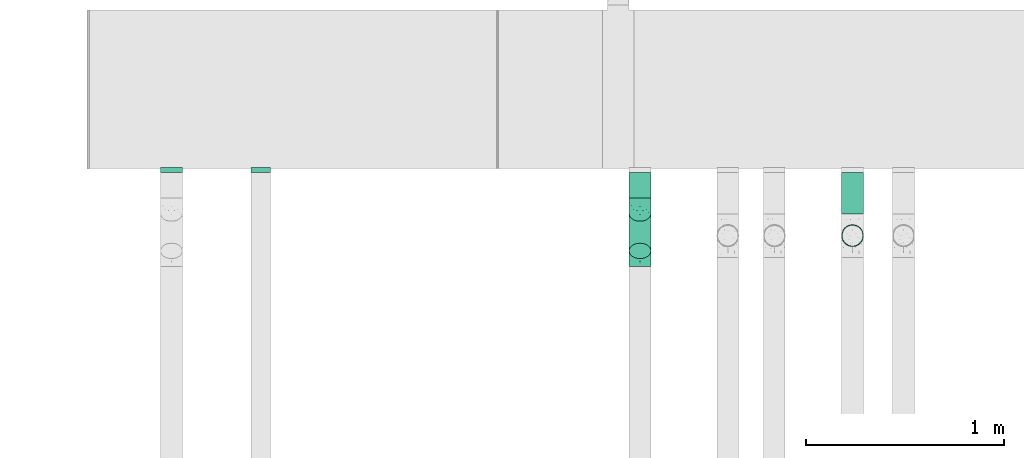
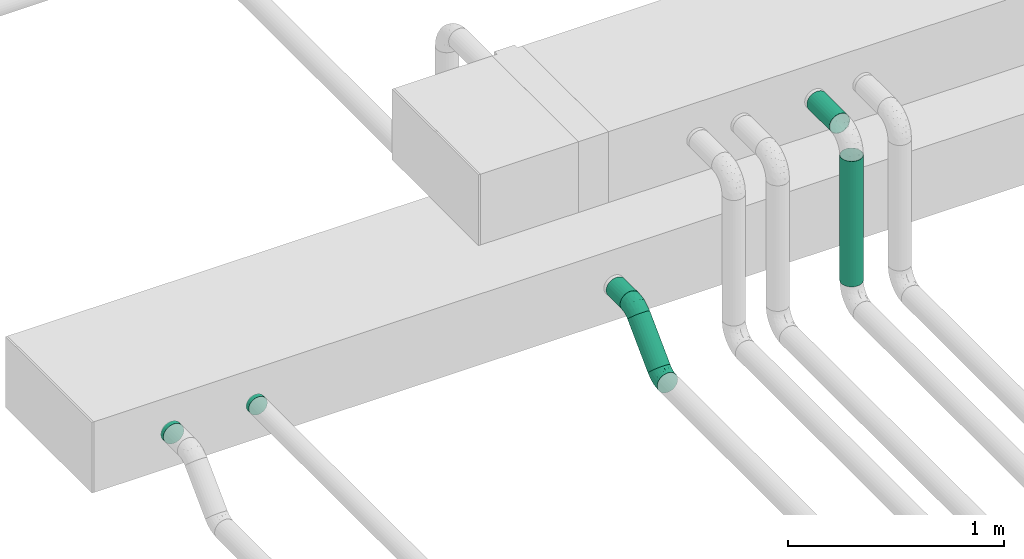
# One storey, part 6 of 91: 4 flow fittings, 4 flow segments.
"""IFC2X3 building model written with IfcOpenShell, lengths in millimetres."""

from ifc_helpers import new_model, entity, si_unit, converted_unit, derived_unit, direction, frame, origin_with_axes, origin_2d_with_axis, place, context, subcontext, project, spatial, hollow_circle, extrude, open_shell, surface_model, source, transform, mapped, material, layer, layer_set, layer_usage, type_object, element, save


model = new_model("IFC2X3")

# Units and contexts
model_context = context("Model", 3, precision=1e-05, world=origin_with_axes(), true_north=direction((0.0, 1.0)))
body_context = subcontext(model_context, "Body", "Model", "MODEL_VIEW")
ifc_project = project(units=[si_unit("AREAUNIT", "SQUARE_METRE"), si_unit("VOLUMEUNIT", "CUBIC_METRE", prefix="DECI"), si_unit("TIMEUNIT", "SECOND"), si_unit("THERMODYNAMICTEMPERATUREUNIT", "DEGREE_CELSIUS"), si_unit("PRESSUREUNIT", "PASCAL"), si_unit("MASSUNIT", "GRAM", prefix="KILO"), si_unit("LENGTHUNIT", "METRE", prefix="MILLI"), si_unit("POWERUNIT", "WATT"), si_unit("ELECTRICCURRENTUNIT", "AMPERE"), si_unit("ELECTRICVOLTAGEUNIT", "VOLT"), derived_unit("VOLUMETRICFLOWRATEUNIT", [(si_unit("VOLUMEUNIT", "CUBIC_METRE", prefix="DECI"), 1), (si_unit("TIMEUNIT", "SECOND"), -1)]), derived_unit("LINEARVELOCITYUNIT", [(si_unit("LENGTHUNIT", "METRE"), 1), (si_unit("TIMEUNIT", "SECOND"), -1)]), derived_unit("MASSDENSITYUNIT", [(si_unit("MASSUNIT", "GRAM", prefix="KILO"), 1), (si_unit("VOLUMEUNIT", "CUBIC_METRE"), -1)]), converted_unit("PLANEANGLEUNIT", "DEGREE", entity("IfcRatioMeasure", 0.01745), si_unit("PLANEANGLEUNIT", "RADIAN"), dimensions=[0, 0, 0, 0, 0, 0, 0])], contexts=[model_context])

# Site, building, storey
site_placement = place(None, origin_with_axes())
site = spatial("IfcSite", under=ifc_project, at=site_placement, CompositionType="ELEMENT")
building_placement = place(site_placement, origin_with_axes())
building = spatial("IfcBuilding", under=site, at=building_placement, Name="mc-building", CompositionType="ELEMENT")
storey_placement = place(building_placement, frame((0.0, 0.0, 8700.0), z_axis=(0.0, 0.0, 1.0), x_axis=(1.0, 0.0, 0.0)))
storey = spatial("IfcBuildingStorey", under=building, at=storey_placement, CompositionType="ELEMENT", Elevation=8700.0)

# Flow segments
ifc_material = material(Name="FZ1")
ifc_layer = layer(ifc_material, 0.0)
ifc_layer_set = layer_set([ifc_layer], Name="FZ1")
ifc_layer_usage = layer_usage(ifc_layer_set, "AXIS1", "POSITIVE", 0.0)
duct_segment_type = type_object("IfcDuctSegmentType", PredefinedType="RIGIDSEGMENT")
shared_shape_1 = source(origin_with_axes(), body_context, "Body", "SweptSolid", [
    extrude(hollow_circle(Radius=55.0, WallThickness=2.0, at=origin_2d_with_axis()), frame((0.0, 0.0, 0.0), z_axis=(1.0, 0.0, 0.0), x_axis=(0.0, 1.0, 0.0)), (0.0, 0.0, 1.0), 709.0),
])
flow_segment_1_placement = place(storey_placement, frame((8987.56202, 2612.35324, 1234.0), z_axis=(0.0, 1.0, 0.0), x_axis=(0.0, 0.0, -1.0)))
element("IfcFlowSegment", 1, at=flow_segment_1_placement, inside=storey, type_object=duct_segment_type, material=ifc_layer_usage, context=body_context, shape_type="MappedRepresentation", body=[
    mapped(shared_shape_1, transform((0.0, 0.0, 0.0), scale=1.0)),
])
shared_shape_2 = source(origin_with_axes(), body_context, "Body", "SweptSolid", [
    extrude(hollow_circle(Radius=55.0, WallThickness=2.0, at=origin_2d_with_axis()), frame((0.0, 0.0, 0.0), z_axis=(1.0, 0.0, 0.0), x_axis=(0.0, 1.0, 0.0)), (0.0, 0.0, 1.0), 208.9),
])
flow_segment_2_placement = place(storey_placement, frame((8987.56202, 2931.20513, 1344.0), z_axis=(0.0, 0.0, 1.0), x_axis=(0.0, -1.0, 0.0)))
element("IfcFlowSegment", 2, at=flow_segment_2_placement, inside=storey, type_object=duct_segment_type, material=ifc_layer_usage, context=body_context, shape_type="MappedRepresentation", body=[
    mapped(shared_shape_2, transform((0.0, 0.0, 0.0), scale=1.0, scale2=1.0, scale3=1.0, uniform=False)),
])
shared_shape_3 = source(origin_with_axes(), body_context, "Body", "SweptSolid", [
    extrude(hollow_circle(Radius=55.0, WallThickness=2.0, at=origin_2d_with_axis()), frame((0.0, 0.0, 0.0), z_axis=(1.0, 0.0, 0.0), x_axis=(0.0, 1.0, 0.0)), (0.0, 0.0, 1.0), 266.7),
])
flow_segment_3_placement = place(storey_placement, frame((7914.47808, 2723.75077, 635.78175), z_axis=(0.0, -0.707107, 0.707107), x_axis=(0.0, -0.707107, -0.707107)))
element("IfcFlowSegment", 3, at=flow_segment_3_placement, inside=storey, type_object=duct_segment_type, material=ifc_layer_usage, context=body_context, shape_type="MappedRepresentation", body=[
    mapped(shared_shape_3, transform((0.0, 0.0, 0.0), scale=1.0)),
])

# Flow fittings
duct_fitting_type_1 = type_object("IfcDuctFittingType", Name="BU", PredefinedType="BEND")
shared_shape_4 = source(origin_with_axes(), body_context, "Body", "SurfaceModel", [
    surface_model("IfcShellBasedSurfaceModel", [(-45.56349, 0.0, -55.0), (-45.56349, -14.23505, -53.12592), (-45.56349, 14.23505, -53.12592), (-45.56349, 53.12592, 14.23505), (-45.56349, 27.5, -47.63139), (-45.56349, 38.89087, -38.89087), (-45.56349, 47.63139, -27.5), (-45.56349, -55.0, 0.0), (-45.56349, -53.12592, 14.23505), (-45.56349, -38.89087, -38.89087), (-45.56349, -27.5, -47.63139), (-45.56349, -53.12592, -14.23505), (-45.56349, -47.63139, -27.5), (-45.56349, 53.12592, -14.23505), (-45.56349, 47.63139, 27.5), (-45.56349, 38.89087, 38.89087), (-45.56349, -14.23505, 53.12592), (-45.56349, 27.5, 47.63139), (-45.56349, 14.23505, 53.12592), (-45.56349, -47.63139, 27.5), (-45.56349, -38.89087, 38.89087), (-45.56349, -27.5, 47.63139), (-45.56349, 0.0, 55.0), (-45.56349, 55.0, 0.0), (22.15256, 42.28395, -53.12592), (-6.67262, 71.10913, 0.0), (32.21826, 32.21826, -55.0), (12.77282, 51.66369, -47.63139), (-1.46223, 65.89874, -27.5), (4.71825, 59.71825, -38.89087), (59.71825, 4.71825, -38.89087), (69.78395, -5.34744, 14.23505), (51.66369, 12.77282, -47.63139), (42.28395, 22.15256, -53.12592), (65.89874, -1.46223, -27.5), (69.78395, -5.34744, -14.23505), (71.10913, -6.67262, 0.0), (-5.34744, 69.78395, -14.23505), (-5.34744, 69.78395, 14.23505), (-1.46223, 65.89874, 27.5), (4.71825, 59.71825, 38.89087), (32.21826, 32.21826, 55.0), (12.77282, 51.66369, 47.63139), (22.15256, 42.28395, 53.12592), (59.71825, 4.71825, 38.89087), (65.89874, -1.46223, 27.5), (42.28395, 22.15256, 53.12592), (51.66369, 12.77282, 47.63139), (-20.16649, 48.68621, 33.48188), (-26.97111, 35.77503, 43.63444), (-7.30443, 43.73336, 43.63444), (-17.0934, 3.74816, 55.0), (-18.00408, 15.44793, 53.78143), (-30.11707, 22.39897, 50.81337), (-7.49776, 55.63651, 33.48188), (-15.97018, 58.74288, 21.04759), (-31.18231, 52.58712, 21.04759), (-18.35174, 61.03934, 10.51509), (-28.67677, 56.60048, 10.47121), (-34.03924, 44.64267, 33.48188), (-11.52288, 27.81868, 50.81338), (1.19951, 23.16465, 53.81115), (-33.77926, 57.34403, 0.0), (5.4586, 37.12132, 50.81809), (-24.5159, 59.18663, 0.0), (-16.66281, 64.4339, 0.0), (9.43651, 14.73721, 55.0), (-6.22531, 44.36822, -43.63444), (5.4586, 37.12132, -50.81809), (-34.03924, 44.64267, -33.48188), (9.43651, 14.73721, -55.0), (-17.0934, 3.74816, -55.0), (1.19951, 23.16465, -53.81115), (-11.52288, 27.81868, -50.81338), (-30.11707, 22.39897, -50.81337), (-25.75914, 36.08917, -43.63444), (-30.24487, 52.83011, -21.04759), (-20.16649, 48.68621, -33.48188), (-7.49776, 55.63651, -33.48188), (-18.00408, 15.44793, -53.78143), (-28.68366, 56.62226, -10.35271), (-14.15883, 63.53074, -10.87592), (-15.13548, 59.23394, -21.04759), (3.19797, -7.72059, -52.16847), (3.1272, -18.04126, -47.9241), (13.63233, -32.91136, -32.06475), (45.23618, -22.99734, -20.4997), (16.67434, -40.25541, -15.9539), (-17.3935, -51.68264, -9.80849), (-2.85835, -49.37776, 0.0), (48.84421, -24.24609, -9.80849), (-16.38424, -42.76862, -30.85433), (-6.97383, -29.41689, -42.70541), (41.82739, -18.65658, -30.85433), (-15.72523, -48.24839, -20.4997), (29.28945, -13.63928, -42.80781), (26.81493, -3.56603, -49.15704), (36.93651, -32.89419, 0.0), (-15.72523, -48.24839, 20.4997), (-17.3935, -51.68264, 9.80849), (-16.38424, -42.76862, 30.85433), (16.67434, -40.25541, 15.9539), (3.19797, -7.72059, 52.16847), (10.54583, -14.96836, 47.9241), (13.63233, -32.91136, 32.06475), (45.23618, -22.99734, 20.4997), (41.82739, -18.65658, 30.85433), (-11.06635, -30.3552, 42.80781), (25.73213, -15.86964, 42.70541), (-16.43945, -21.48258, 49.15704), (48.84421, -24.24609, 9.80849)], [open_shell([[[0, 1, 2]], [[2, 3, 4]], [[5, 3, 6]], [[4, 3, 5]], [[2, 7, 8]], [[9, 7, 10]], [[1, 10, 7]], [[11, 7, 12]], [[9, 12, 7]], [[7, 2, 1]], [[13, 6, 3]], [[14, 3, 2]], [[15, 14, 2]], [[16, 17, 2]], [[2, 17, 15]], [[16, 18, 17]], [[19, 20, 2]], [[19, 2, 8]], [[20, 21, 2]], [[2, 21, 16]], [[16, 22, 18]], [[23, 13, 3]], [[24, 25, 26]], [[27, 25, 24]], [[28, 25, 29]], [[29, 25, 27]], [[30, 26, 31]], [[26, 30, 32]], [[32, 33, 26]], [[34, 31, 35]], [[31, 34, 30]], [[35, 31, 36]], [[37, 25, 28]], [[26, 38, 39]], [[26, 39, 40]], [[41, 40, 42]], [[26, 40, 41]], [[42, 43, 41]], [[26, 44, 45]], [[31, 26, 45]], [[46, 47, 26]], [[47, 44, 26]], [[46, 26, 41]], [[26, 25, 38]], [[48, 49, 50]], [[22, 51, 52]], [[17, 49, 15]], [[53, 17, 18]], [[49, 17, 53]], [[54, 50, 40]], [[48, 55, 56]], [[55, 57, 58]], [[59, 14, 15]], [[60, 53, 52]], [[50, 49, 60]], [[58, 3, 56]], [[52, 51, 61]], [[62, 23, 3]], [[63, 50, 60]], [[50, 42, 40]], [[3, 58, 62]], [[43, 61, 41]], [[62, 58, 64]], [[48, 59, 49]], [[14, 56, 3]], [[40, 39, 54]], [[57, 64, 58]], [[39, 38, 55]], [[63, 60, 61]], [[54, 55, 48]], [[65, 57, 38]], [[56, 14, 59]], [[38, 25, 65]], [[60, 52, 61]], [[49, 59, 15]], [[55, 58, 56]], [[56, 59, 48]], [[55, 54, 39]], [[50, 54, 48]], [[18, 22, 52]], [[49, 53, 60]], [[18, 52, 53]], [[61, 51, 66]], [[41, 61, 66]], [[63, 61, 43]], [[43, 42, 63]], [[50, 63, 42]], [[38, 57, 55]], [[64, 57, 65]], [[67, 27, 68]], [[69, 5, 6]], [[70, 71, 72]], [[73, 74, 75]], [[76, 77, 69]], [[29, 78, 28]], [[2, 79, 0]], [[13, 23, 62]], [[2, 74, 79]], [[5, 75, 4]], [[77, 78, 67]], [[13, 62, 80]], [[64, 80, 62]], [[81, 80, 64]], [[67, 73, 75]], [[82, 77, 76]], [[81, 64, 65]], [[76, 69, 6]], [[82, 76, 80]], [[24, 72, 68]], [[74, 2, 4]], [[27, 67, 29]], [[26, 70, 72]], [[69, 75, 5]], [[82, 28, 78]], [[72, 71, 79]], [[6, 13, 76]], [[77, 67, 75]], [[13, 80, 76]], [[82, 37, 28]], [[81, 25, 37]], [[82, 81, 37]], [[75, 69, 77]], [[67, 78, 29]], [[82, 78, 77]], [[75, 74, 4]], [[79, 74, 73]], [[79, 73, 72]], [[79, 71, 0]], [[68, 72, 73]], [[26, 72, 24]], [[67, 68, 73]], [[27, 24, 68]], [[80, 81, 82]], [[25, 81, 65]], [[1, 83, 84]], [[85, 86, 87]], [[0, 71, 1]], [[88, 87, 89]], [[90, 86, 35]], [[91, 92, 85]], [[11, 88, 7]], [[30, 34, 93]], [[11, 12, 94]], [[92, 91, 9]], [[85, 94, 91]], [[94, 85, 87]], [[95, 93, 85]], [[85, 92, 95]], [[83, 71, 70]], [[12, 9, 91]], [[70, 26, 33]], [[96, 84, 83]], [[1, 71, 83]], [[95, 96, 32]], [[95, 30, 93]], [[95, 32, 30]], [[97, 89, 87]], [[34, 86, 93]], [[36, 97, 90]], [[94, 88, 11]], [[34, 35, 86]], [[90, 87, 86]], [[93, 86, 85]], [[32, 96, 33]], [[84, 10, 1]], [[33, 83, 70]], [[94, 12, 91]], [[10, 92, 9]], [[87, 88, 94]], [[7, 88, 89]], [[36, 90, 35]], [[87, 90, 97]], [[84, 95, 92]], [[33, 96, 83]], [[95, 84, 96]], [[10, 84, 92]], [[8, 98, 19]], [[7, 89, 99]], [[19, 98, 100]], [[101, 98, 99]], [[46, 102, 103]], [[104, 105, 106]], [[100, 98, 104]], [[107, 104, 108]], [[16, 51, 22]], [[51, 16, 102]], [[107, 20, 100]], [[107, 109, 21]], [[21, 20, 107]], [[103, 47, 46]], [[101, 89, 97]], [[105, 110, 31]], [[44, 47, 108]], [[105, 104, 101]], [[107, 100, 104]], [[31, 110, 36]], [[109, 16, 21]], [[108, 106, 44]], [[105, 45, 106]], [[41, 66, 46]], [[102, 66, 51]], [[46, 66, 102]], [[104, 98, 101]], [[99, 98, 8]], [[106, 108, 104]], [[110, 101, 97]], [[45, 44, 106]], [[105, 31, 45]], [[20, 19, 100]], [[109, 103, 102]], [[101, 110, 105]], [[36, 110, 97]], [[7, 99, 8]], [[101, 99, 89]], [[103, 107, 108]], [[16, 109, 102]], [[107, 103, 109]], [[47, 103, 108]]])]),
])
for number, where, z_axis, x_axis, name in (
    (4, (7914.47808, 2755.96902, 668.0), (-1.0, 0.0, 0.0), (0.0, 0.707107, 0.707107), "BU"),
    (5, (7914.47808, 2502.96902, 415.0), (1.0, 0.0, 0.0), (0.0, 1.0, 0.0), "BU"),
):
    element("IfcFlowFitting", number, at=place(storey_placement, frame(where, z_axis=z_axis, x_axis=x_axis)), inside=storey, type_object=duct_fitting_type_1, Name=name, context=body_context, shape_type="MappedRepresentation", body=[
        mapped(shared_shape_4, transform((0.0, 0.0, 0.0), scale=1.0)),
    ])

# Flow segment
shared_shape_5 = source(origin_with_axes(), body_context, "Body", "SweptSolid", [
    extrude(hollow_circle(Radius=55.0, WallThickness=2.0, at=origin_2d_with_axis()), frame((0.0, 0.0, 0.0), z_axis=(1.0, 0.0, 0.0), x_axis=(0.0, 1.0, 0.0)), (0.0, 0.0, 1.0), 129.7),
])
flow_segment_4_placement = place(storey_placement, frame((7914.47808, 2931.20513, 668.0), z_axis=(0.0, 0.0, 1.0), x_axis=(0.0, -1.0, 0.0)))
element("IfcFlowSegment", 6, at=flow_segment_4_placement, inside=storey, type_object=duct_segment_type, material=ifc_layer_usage, context=body_context, shape_type="MappedRepresentation", body=[
    mapped(shared_shape_5, transform((0.0, 0.0, 0.0), scale=1.0)),
])

# Flow fittings
duct_fitting_type_2 = type_object("IfcDuctFittingType", Name="CC", PredefinedType="CONNECTOR")
shared_shape_6 = source(origin_with_axes(), body_context, "Body", "SurfaceModel", [
    surface_model("IfcShellBasedSurfaceModel", [(-6.096, -38.89087, -38.89087), (-6.096, -55.0, 0.0), (-6.096, -27.5, -47.63139), (-6.096, 47.63139, -27.5), (-6.096, 53.12592, 14.23505), (-6.096, 53.12592, -14.23505), (-6.096, 55.0, 0.0), (-6.096, -53.12592, -14.23505), (-6.096, -47.63139, -27.5), (20.0, 38.89087, -38.89087), (20.0, 55.0, 0.0), (20.0, 27.5, -47.63139), (20.0, 53.12592, -14.23505), (20.0, 47.63139, -27.5), (20.0, -47.63139, -27.5), (20.0, -53.12592, 14.23505), (20.0, -53.12592, -14.23505), (20.0, -55.0, 0.0), (-6.096, 0.0, -55.0), (-6.096, -14.23505, -53.12592), (-6.096, 14.23505, -53.12592), (-6.096, 27.5, -47.63139), (-6.096, 38.89087, -38.89087), (-6.096, -53.12592, 14.23505), (-6.096, 47.63139, 27.5), (-6.096, 38.89087, 38.89087), (-6.096, -14.23505, 53.12592), (-6.096, 27.5, 47.63139), (-6.096, 14.23505, 53.12592), (-6.096, -47.63139, 27.5), (-6.096, -38.89087, 38.89087), (-6.096, -27.5, 47.63139), (-6.096, 0.0, 55.0), (0.0, 0.0, 55.0), (0.0, 14.23505, 53.12592), (0.0, 27.5, 47.63139), (0.0, 38.89087, 38.89087), (0.0, 47.63139, 27.5), (0.0, 53.12592, 14.23505), (0.0, 55.0, 0.0), (0.0, 53.12592, -14.23505), (0.0, 47.63139, -27.5), (0.0, 38.89087, -38.89087), (0.0, 27.5, -47.63139), (0.0, 14.23505, -53.12592), (0.0, 0.0, -55.0), (0.0, -14.23505, -53.12592), (0.0, -27.5, -47.63139), (0.0, -38.89087, -38.89087), (0.0, -47.63139, -27.5), (0.0, -53.12592, -14.23505), (0.0, -55.0, 0.0), (0.0, -53.12592, 14.23505), (0.0, -47.63139, 27.5), (0.0, -38.89087, 38.89087), (0.0, -27.5, 47.63139), (0.0, -14.23505, 53.12592), (20.0, 0.0, -55.0), (20.0, 14.23505, -53.12592), (20.0, -38.89087, -38.89087), (20.0, -27.5, -47.63139), (20.0, -14.23505, -53.12592), (20.0, 53.12592, 14.23505), (20.0, 47.63139, 27.5), (20.0, 38.89087, 38.89087), (20.0, 0.0, 55.0), (20.0, 27.5, 47.63139), (20.0, 14.23505, 53.12592), (20.0, -38.89087, 38.89087), (20.0, -47.63139, 27.5), (20.0, -14.23505, 53.12592), (20.0, -27.5, 47.63139)], [open_shell([[[0, 1, 2]], [[3, 4, 5]], [[6, 5, 4]], [[7, 1, 8]], [[9, 10, 11]], [[12, 10, 13]], [[14, 15, 16]], [[17, 16, 15]], [[18, 19, 20]], [[20, 4, 21]], [[3, 22, 4]], [[21, 4, 22]], [[20, 1, 23]], [[19, 2, 1]], [[0, 8, 1]], [[1, 20, 19]], [[20, 24, 4]], [[25, 24, 20]], [[26, 27, 20]], [[27, 25, 20]], [[26, 28, 27]], [[20, 29, 30]], [[29, 20, 23]], [[30, 31, 20]], [[20, 31, 26]], [[26, 32, 28]], [[32, 33, 34]], [[28, 34, 35]], [[32, 34, 28]], [[27, 36, 25]], [[27, 28, 35]], [[36, 27, 35]], [[24, 37, 38]], [[4, 38, 39]], [[25, 37, 24]], [[4, 24, 38]], [[6, 4, 39]], [[37, 25, 36]], [[6, 39, 40]], [[5, 40, 41]], [[6, 40, 5]], [[3, 42, 22]], [[3, 5, 41]], [[42, 3, 41]], [[21, 43, 44]], [[20, 44, 45]], [[22, 43, 21]], [[20, 21, 44]], [[18, 20, 45]], [[43, 22, 42]], [[18, 45, 46]], [[19, 46, 47]], [[18, 46, 19]], [[2, 48, 0]], [[2, 19, 47]], [[48, 2, 47]], [[8, 49, 50]], [[7, 50, 51]], [[0, 49, 8]], [[7, 8, 50]], [[1, 7, 51]], [[49, 0, 48]], [[1, 51, 52]], [[23, 52, 53]], [[1, 52, 23]], [[29, 54, 30]], [[29, 23, 53]], [[54, 29, 53]], [[31, 55, 56]], [[26, 56, 33]], [[30, 55, 31]], [[26, 31, 56]], [[32, 26, 33]], [[55, 30, 54]], [[10, 57, 58]], [[11, 10, 58]], [[10, 9, 13]], [[59, 57, 15]], [[57, 59, 60]], [[60, 61, 57]], [[59, 15, 14]], [[62, 63, 57]], [[57, 63, 64]], [[65, 64, 66]], [[65, 57, 64]], [[67, 65, 66]], [[68, 69, 57]], [[15, 57, 69]], [[70, 71, 57]], [[71, 68, 57]], [[70, 57, 65]], [[10, 62, 57]], [[33, 65, 67]], [[34, 67, 66]], [[33, 67, 34]], [[35, 64, 36]], [[35, 34, 66]], [[64, 35, 66]], [[37, 63, 62]], [[38, 62, 10]], [[36, 63, 37]], [[38, 37, 62]], [[39, 38, 10]], [[63, 36, 64]], [[39, 10, 12]], [[40, 12, 13]], [[39, 12, 40]], [[41, 9, 42]], [[41, 40, 13]], [[9, 41, 13]], [[43, 11, 58]], [[44, 58, 57]], [[42, 11, 43]], [[44, 43, 58]], [[45, 44, 57]], [[11, 42, 9]], [[45, 57, 61]], [[46, 61, 60]], [[45, 61, 46]], [[47, 59, 48]], [[47, 46, 60]], [[59, 47, 60]], [[49, 14, 16]], [[50, 16, 17]], [[48, 14, 49]], [[50, 49, 16]], [[51, 50, 17]], [[14, 48, 59]], [[51, 17, 15]], [[52, 15, 69]], [[51, 15, 52]], [[53, 68, 54]], [[53, 52, 69]], [[68, 53, 69]], [[55, 71, 70]], [[56, 70, 65]], [[54, 71, 55]], [[56, 55, 70]], [[33, 56, 65]], [[71, 54, 68]], [[65, 57, 66]], [[57, 64, 66]], [[65, 66, 67]], [[69, 15, 57]]])]),
])
flow_fitting_1_placement = place(storey_placement, frame((5548.85991, 2951.20513, 668.0), z_axis=(0.0, 0.0, -1.0), x_axis=(0.0, -1.0, 0.0)))
element("IfcFlowFitting", 7, at=flow_fitting_1_placement, inside=storey, type_object=duct_fitting_type_2, Name="CC", context=body_context, shape_type="MappedRepresentation", body=[
    mapped(shared_shape_6, transform((0.0, 0.0, 0.0), scale=1.0)),
])
shared_shape_7 = source(origin_with_axes(), body_context, "Body", "SurfaceModel", [
    surface_model("IfcShellBasedSurfaceModel", [(-6.096, -35.35534, -35.35534), (-6.096, -50.0, 0.0), (-6.096, -25.0, -43.30127), (-6.096, 43.30127, -25.0), (-6.096, 48.29629, 12.94095), (-6.096, 48.29629, -12.94095), (20.0, -43.30127, -25.0), (20.0, -35.35534, -35.35534), (20.0, -48.29629, 12.94095), (20.0, 35.35534, -35.35534), (20.0, 50.0, 0.0), (20.0, 25.0, -43.30127), (20.0, -48.29629, -12.94095), (20.0, -50.0, 0.0), (-6.096, 0.0, -50.0), (-6.096, -12.94095, -48.29629), (-6.096, 12.94095, -48.29629), (-6.096, 25.0, -43.30127), (-6.096, 35.35534, -35.35534), (-6.096, -48.29629, 12.94095), (-6.096, -48.29629, -12.94095), (-6.096, -43.30127, -25.0), (-6.096, 43.30127, 25.0), (-6.096, 35.35534, 35.35534), (-6.096, 25.0, 43.30127), (-6.096, -12.94095, 48.29629), (-6.096, 12.94095, 48.29629), (-6.096, -43.30127, 25.0), (-6.096, -35.35534, 35.35534), (-6.096, -25.0, 43.30127), (-6.096, 0.0, 50.0), (-6.096, 50.0, 0.0), (0.0, 0.0, 50.0), (0.0, 12.94095, 48.29629), (0.0, 25.0, 43.30127), (0.0, 35.35534, 35.35534), (0.0, 43.30127, 25.0), (0.0, 48.29629, 12.94095), (0.0, 50.0, 0.0), (0.0, 48.29629, -12.94095), (0.0, 43.30127, -25.0), (0.0, 35.35534, -35.35534), (0.0, 25.0, -43.30127), (0.0, 12.94095, -48.29629), (0.0, 0.0, -50.0), (0.0, -12.94095, -48.29629), (0.0, -25.0, -43.30127), (0.0, -35.35534, -35.35534), (0.0, -43.30127, -25.0), (0.0, -48.29629, -12.94095), (0.0, -50.0, 0.0), (0.0, -48.29629, 12.94095), (0.0, -43.30127, 25.0), (0.0, -35.35534, 35.35534), (0.0, -25.0, 43.30127), (0.0, -12.94095, 48.29629), (20.0, 12.94095, -48.29629), (20.0, 0.0, -50.0), (20.0, 43.30127, -25.0), (20.0, -25.0, -43.30127), (20.0, -12.94095, -48.29629), (20.0, 48.29629, -12.94095), (20.0, 48.29629, 12.94095), (20.0, 43.30127, 25.0), (20.0, 35.35534, 35.35534), (20.0, 25.0, 43.30127), (20.0, 0.0, 50.0), (20.0, 12.94095, 48.29629), (20.0, -43.30127, 25.0), (20.0, -35.35534, 35.35534), (20.0, -25.0, 43.30127), (20.0, -12.94095, 48.29629)], [open_shell([[[0, 1, 2]], [[3, 4, 5]], [[6, 7, 8]], [[9, 10, 11]], [[6, 8, 12]], [[13, 12, 8]], [[14, 15, 16]], [[16, 4, 17]], [[3, 18, 4]], [[17, 4, 18]], [[16, 1, 19]], [[15, 2, 1]], [[20, 1, 21]], [[0, 21, 1]], [[1, 16, 15]], [[22, 4, 16]], [[23, 22, 16]], [[24, 16, 25]], [[24, 23, 16]], [[24, 25, 26]], [[19, 27, 16]], [[16, 27, 28]], [[16, 28, 29]], [[25, 16, 29]], [[25, 30, 26]], [[31, 5, 4]], [[30, 32, 33]], [[26, 33, 34]], [[30, 33, 26]], [[24, 35, 23]], [[24, 26, 34]], [[35, 24, 34]], [[22, 36, 37]], [[4, 37, 38]], [[23, 36, 22]], [[4, 22, 37]], [[31, 4, 38]], [[36, 23, 35]], [[31, 38, 39]], [[5, 39, 40]], [[31, 39, 5]], [[3, 41, 18]], [[3, 5, 40]], [[41, 3, 40]], [[17, 42, 43]], [[16, 43, 44]], [[18, 42, 17]], [[16, 17, 43]], [[14, 16, 44]], [[42, 18, 41]], [[14, 44, 45]], [[15, 45, 46]], [[14, 45, 15]], [[2, 47, 0]], [[2, 15, 46]], [[47, 2, 46]], [[21, 48, 49]], [[20, 49, 50]], [[0, 48, 21]], [[20, 21, 49]], [[1, 20, 50]], [[48, 0, 47]], [[1, 50, 51]], [[19, 51, 52]], [[1, 51, 19]], [[27, 53, 28]], [[27, 19, 52]], [[53, 27, 52]], [[29, 54, 55]], [[25, 55, 32]], [[28, 54, 29]], [[25, 29, 55]], [[30, 25, 32]], [[54, 28, 53]], [[56, 10, 57]], [[11, 10, 56]], [[10, 9, 58]], [[7, 57, 8]], [[57, 7, 59]], [[59, 60, 57]], [[8, 6, 7]], [[12, 8, 13]], [[58, 61, 10]], [[57, 62, 63]], [[57, 63, 64]], [[65, 66, 64]], [[66, 57, 64]], [[67, 66, 65]], [[57, 68, 8]], [[69, 68, 57]], [[70, 69, 57]], [[71, 70, 57]], [[71, 57, 66]], [[57, 10, 62]], [[32, 66, 67]], [[33, 67, 65]], [[32, 67, 33]], [[34, 64, 35]], [[34, 33, 65]], [[64, 34, 65]], [[36, 63, 62]], [[37, 62, 10]], [[35, 63, 36]], [[37, 36, 62]], [[38, 37, 10]], [[63, 35, 64]], [[38, 10, 61]], [[39, 61, 58]], [[38, 61, 39]], [[40, 9, 41]], [[40, 39, 58]], [[9, 40, 58]], [[42, 11, 56]], [[43, 56, 57]], [[41, 11, 42]], [[43, 42, 56]], [[44, 43, 57]], [[11, 41, 9]], [[44, 57, 60]], [[45, 60, 59]], [[44, 60, 45]], [[46, 7, 47]], [[46, 45, 59]], [[7, 46, 59]], [[48, 6, 12]], [[49, 12, 13]], [[47, 6, 48]], [[49, 48, 12]], [[50, 49, 13]], [[6, 47, 7]], [[50, 13, 8]], [[51, 8, 68]], [[50, 8, 51]], [[52, 69, 53]], [[52, 51, 68]], [[69, 52, 68]], [[54, 70, 71]], [[55, 71, 66]], [[53, 70, 54]], [[55, 54, 71]], [[32, 55, 66]], [[70, 53, 69]], [[68, 8, 57]], [[70, 57, 71]], [[66, 71, 57]], [[10, 62, 57]], [[25, 24, 16]], [[25, 26, 24]]])]),
])
flow_fitting_2_placement = place(storey_placement, frame((6000.0, 2951.20513, 668.0), z_axis=(0.0, 0.0, -1.0), x_axis=(0.0, -1.0, 0.0)))
element("IfcFlowFitting", 8, at=flow_fitting_2_placement, inside=storey, type_object=duct_fitting_type_2, Name="CC", context=body_context, shape_type="MappedRepresentation", body=[
    mapped(shared_shape_7, transform((0.0, 0.0, 0.0), scale=1.0)),
])

save(model, "model.ifc")
